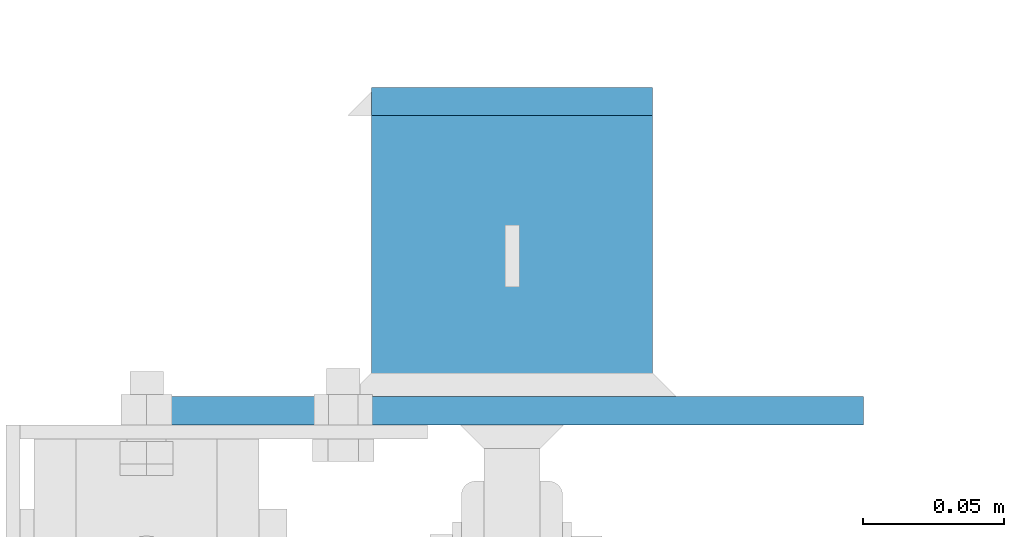
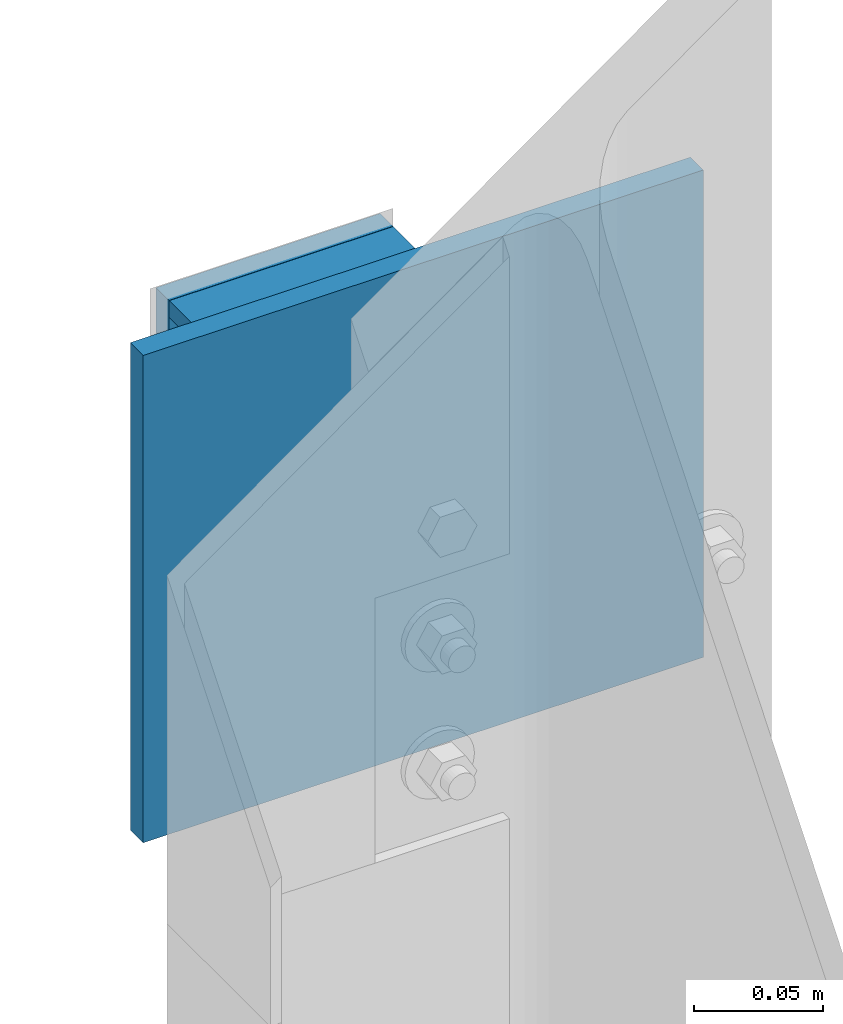
# One storey, part 94 of 496: 3 beams, 1 element without a shape of its own.
"""IFC2X3 building model written with IfcOpenShell, lengths in millimetres."""

import ifcopenshell
import ifcopenshell.guid

model = None  # the IFC model being written
_history = None  # IfcOwnerHistory: only IFC2X3 demands one
_inside = {}  # id of a spatial element -> (the spatial element, [elements in it])
_under = {}  # id of a project, library or spatial element -> (it, [spatial elements below it])
_declared = {}  # id of a project -> (the project, [libraries it declares])
_typed = {}  # id of a type object -> (the type object, [elements of that type])
_made_of = {}  # id of a material, layer set ... -> (it, [elements and type objects made of it])


def new_model(schema):
    """Start an empty IFC model of exactly this schema.

    Asked for "IFC4X3", IfcOpenShell would pick the latest addendum, in which some entities
    have other attributes; the version numbers below select the first issue.
    IFC2X3 requires an IfcOwnerHistory on every rooted entity: one is made here for all.
    """
    global model, _history
    if schema == "IFC4X3":
        model = ifcopenshell.file(schema_version=(4, 3, 0, 0))
    else:
        model = ifcopenshell.file(schema=schema)
    _inside.clear()
    _under.clear()
    _declared.clear()
    _typed.clear()
    _made_of.clear()
    _history = None
    if model.schema == "IFC2X3":
        org = make("IfcOrganization", Name="unknown")
        user = make(
            "IfcPersonAndOrganization",
            ThePerson=make("IfcPerson", FamilyName="unknown"),
            TheOrganization=org,
        )
        app = make(
            "IfcApplication",
            ApplicationDeveloper=org,
            Version="unknown",
            ApplicationFullName="unknown",
            ApplicationIdentifier="unknown",
        )
        _history = make(
            "IfcOwnerHistory",
            OwningUser=user,
            OwningApplication=app,
            ChangeAction="ADDED",
            CreationDate=0,
        )
    return model


def make(cls, **values):
    """One entity of the class cls with the attributes given. An attribute that is None is left unset."""
    return model.create_entity(
        cls, **{name: value for name, value in values.items() if value is not None}
    )


def rooted(cls, **values):
    """An entity with a GlobalId (a new one), such as an element, a storey or a relation."""
    return make(cls, GlobalId=ifcopenshell.guid.new(), OwnerHistory=_history, **values)


def si_unit(unit_type, name, prefix=None):
    """IfcSIUnit, for example si_unit("LENGTHUNIT", "METRE", prefix="MILLI")."""
    return make("IfcSIUnit", UnitType=unit_type, Prefix=prefix, Name=name)


def assignment(units):
    """IfcUnitAssignment: the units of a project."""
    return None if units is None else make("IfcUnitAssignment", Units=units)


def point(xyz):
    """IfcCartesianPoint."""
    return None if xyz is None else make("IfcCartesianPoint", Coordinates=xyz)


def direction(xyz):
    """IfcDirection."""
    return None if xyz is None else make("IfcDirection", DirectionRatios=xyz)


def frame(location, z_axis=None, x_axis=None):
    """IfcAxis2Placement3D, a coordinate frame: its origin and axes. An axis left out is left unset."""
    return make(
        "IfcAxis2Placement3D",
        Location=point(location),
        Axis=direction(z_axis),
        RefDirection=direction(x_axis),
    )


def frame_2d(location, x_axis=None):
    """IfcAxis2Placement2D, a coordinate frame in the plane: its origin and x axis."""
    return make(
        "IfcAxis2Placement2D", Location=point(location), RefDirection=direction(x_axis)
    )


def origin_with_axes():
    """The frame at (0, 0, 0) with the z axis (0, 0, 1) and the x axis (1, 0, 0) written out."""
    return frame((0.0, 0.0, 0.0), z_axis=(0.0, 0.0, 1.0), x_axis=(1.0, 0.0, 0.0))


def origin_2d_with_axis():
    """The frame at (0, 0) in the plane with the x axis (1, 0) written out."""
    return frame_2d((0.0, 0.0), x_axis=(1.0, 0.0))


def place(relative_to, where):
    """IfcLocalPlacement: puts the frame where relative to a parent placement (None: the world)."""
    return make(
        "IfcLocalPlacement", PlacementRelTo=relative_to, RelativePlacement=where
    )


def context(
    kind, dimensions, precision=None, world=None, true_north=None, identifier=None
):
    """IfcGeometricRepresentationContext, for example the 3D "Model" context."""
    return make(
        "IfcGeometricRepresentationContext",
        ContextIdentifier=identifier,
        ContextType=kind,
        CoordinateSpaceDimension=dimensions,
        Precision=precision,
        WorldCoordinateSystem=world,
        TrueNorth=true_north,
    )


def subcontext(parent, identifier, kind, view, scale=None):
    """IfcGeometricRepresentationSubContext, for example "Body" below "Model"."""
    return make(
        "IfcGeometricRepresentationSubContext",
        ContextIdentifier=identifier,
        ContextType=kind,
        ParentContext=parent,
        TargetScale=scale,
        TargetView=view,
    )


def project(units=None, contexts=None):
    """IfcProject with its units and contexts."""
    return rooted(
        "IfcProject",
        Name="project",
        RepresentationContexts=contexts,
        UnitsInContext=assignment(units),
    )


def spatial(cls, under=None, at=None, **own):
    """A site, building, storey or space (cls), placed at a placement, below another one or the project."""
    s = rooted(cls, ObjectPlacement=at, **own)
    if under is not None:
        _under.setdefault(under.id(), (under, []))[1].append(s)
    return s


def profile(cls, at=None, kind="AREA", **sizes):
    """A parametric profile (cls). Its sizes go by their IFC names, for example OverallWidth=200.0."""
    return make(cls, ProfileType=kind, Position=at, **sizes)


def rectangle(**sizes):
    """IfcRectangleProfileDef."""
    return profile("IfcRectangleProfileDef", **sizes)


def i_section(**sizes):
    """IfcIShapeProfileDef."""
    return profile("IfcIShapeProfileDef", **sizes)


def extrude(swept, where, along, depth):
    """IfcExtrudedAreaSolid: the profile swept, set in the frame where, extruded along a direction by depth."""
    return make(
        "IfcExtrudedAreaSolid",
        SweptArea=swept,
        Position=where,
        ExtrudedDirection=direction(along),
        Depth=depth,
    )


def shape(context_of_items, identifier, shape_type, items):
    """IfcShapeRepresentation: the items that make up one representation, for example the "Body"."""
    return make(
        "IfcShapeRepresentation",
        ContextOfItems=context_of_items,
        RepresentationIdentifier=identifier,
        RepresentationType=shape_type,
        Items=items,
    )


def material(Name=None, Category=None):
    """IfcMaterial."""
    return make("IfcMaterial", Name=Name, Category=Category)


def made_of(thing, what):
    """Note that an element or type object is made of a material, layer set ...; save() writes the relation."""
    if what is not None:
        _made_of.setdefault(what.id(), (what, []))[1].append(thing)
    return thing


def type_object(cls, material=None, **own):
    """A type object (cls), such as IfcWallType, which elements share."""
    return made_of(rooted(cls, **own), material)


def element(
    cls,
    number,
    at=None,
    inside=None,
    cuts=None,
    type_object=None,
    material=None,
    context=None,
    identifier="Body",
    shape_type=None,
    held_by="IfcProductDefinitionShape",
    body=None,
    shapes=None,
    **own,
):
    """One element of the class cls, such as IfcWall. Its Tag is "e" and its number.

    at: its placement. inside: the storey or other place that contains it. cuts: it is an
    opening in that element (IfcRelVoidsElement). A single representation is given by context,
    identifier, shape_type and body (its items); several are given by shapes. held_by: the class
    of the entity that holds the representations. save() writes the other relations.
    """
    e = rooted(cls, Tag="e%d" % number, ObjectPlacement=at, **own)
    if body is not None:
        shapes = [shape(context, identifier, shape_type, body)]
    if shapes is not None:
        e.Representation = make(held_by, Representations=shapes)
    if inside is not None:
        _inside.setdefault(inside.id(), (inside, []))[1].append(e)
    if cuts is not None:
        rooted(
            "IfcRelVoidsElement", RelatingBuildingElement=cuts, RelatedOpeningElement=e
        )
    if type_object is not None:
        _typed.setdefault(type_object.id(), (type_object, []))[1].append(e)
    return made_of(e, material)


def aggregate(whole, parts):
    """IfcRelAggregates: a whole, such as a stair, and the parts it consists of."""
    return rooted("IfcRelAggregates", RelatingObject=whole, RelatedObjects=parts)


def save(model, path):
    """Write the relations noted so far, then the file.

    IfcRelAggregates (storeys below a building ...), IfcRelContainedInSpatialStructure (elements
    in a storey), IfcRelDefinesByType, IfcRelAssociatesMaterial and IfcRelDeclares: one each for
    every whole, place, type object, material and project.
    """
    for whole, parts in _under.values():
        aggregate(whole, parts)
    for where, things in _inside.values():
        rooted(
            "IfcRelContainedInSpatialStructure",
            RelatedElements=things,
            RelatingStructure=where,
        )
    for kind, things in _typed.values():
        rooted("IfcRelDefinesByType", RelatedObjects=things, RelatingType=kind)
    for what, things in _made_of.values():
        rooted("IfcRelAssociatesMaterial", RelatedObjects=things, RelatingMaterial=what)
    for by, libraries in _declared.values():
        rooted("IfcRelDeclares", RelatingContext=by, RelatedDefinitions=libraries)
    model.write(path)


model = new_model("IFC2X3")

# Units and contexts
model_context = context("Model", 3, precision=1e-05, world=origin_with_axes())
body_context = subcontext(model_context, "Body", "Model", "MODEL_VIEW")
ifc_project = project(units=[si_unit("LENGTHUNIT", "METRE", prefix="MILLI"), si_unit("AREAUNIT", "SQUARE_METRE"), si_unit("VOLUMEUNIT", "CUBIC_METRE"), si_unit("MASSUNIT", "GRAM", prefix="KILO"), si_unit("TIMEUNIT", "SECOND"), si_unit("PLANEANGLEUNIT", "RADIAN"), si_unit("SOLIDANGLEUNIT", "STERADIAN"), si_unit("THERMODYNAMICTEMPERATUREUNIT", "DEGREE_CELSIUS"), si_unit("LUMINOUSINTENSITYUNIT", "LUMEN")], contexts=[model_context])

# Site, building, storey
site_placement = place(None, origin_with_axes())
site = spatial("IfcSite", under=ifc_project, at=site_placement, CompositionType="ELEMENT")
building_placement = place(site_placement, origin_with_axes())
building = spatial("IfcBuilding", under=site, at=building_placement, Name="Undefined", CompositionType="ELEMENT")
storey_placement = place(building_placement, origin_with_axes())
storey = spatial("IfcBuildingStorey", under=building, at=storey_placement, Name="Undefined", CompositionType="ELEMENT", Elevation=0.0)

# Assembly, beams
assembly_placement = place(storey_placement, origin_with_axes())
assembly = element("IfcElementAssembly", 1, at=assembly_placement, inside=storey, AssemblyPlace="NOTDEFINED", PredefinedType="NOTDEFINED")
ifc_material_1 = material(Name="Undefined/S235-E24")
beam_type_1 = type_object("IfcBeamType", PredefinedType="NOTDEFINED")
beam_1_placement = place(assembly_placement, frame((0.0, 15505.0, 3363.0), z_axis=(-1.0, 0.0, 0.0), x_axis=(0.0, 0.0, -1.0)))
beam_1 = element("IfcBeam", 2, at=beam_1_placement, type_object=beam_type_1, material=ifc_material_1, Name="PLAT", context=body_context, shape_type="SweptSolid", body=[
    extrude(rectangle(XDim=10.0, YDim=100.0, at=origin_2d_with_axis()), frame((96.0, 0.0, 0.0), z_axis=(-1.0, 0.0, 0.0), x_axis=(0.0, -1.0, 0.0)), (0.0, 0.0, 1.0), 96.0),
])
ifc_material_2 = material(Name="Undefined/S275-E28")
beam_type_2 = type_object("IfcBeamType", Name="HEA100", PredefinedType="NOTDEFINED")
beam_2_placement = place(assembly_placement, frame((0.0, 15400.0, 3315.0), z_axis=(0.0, 0.0, 1.0), x_axis=(0.0, 1.0, 0.0)))
beam_2 = element("IfcBeam", 3, at=beam_2_placement, type_object=beam_type_2, material=ifc_material_2, ObjectType="HEA100", context=body_context, shape_type="SweptSolid", body=[
    extrude(i_section(OverallWidth=100.0, OverallDepth=96.0, WebThickness=5.0, FlangeThickness=8.0, FilletRadius=12.0, at=origin_2d_with_axis()), frame((100.000000000021, 5.72981662116945e-11, -4.09272615797818e-12), z_axis=(-1.0, 0.0, 0.0), x_axis=(0.0, -1.0, 0.0)), (0.0, 0.0, 1.0), 100.0),
])
beam_type_3 = type_object("IfcBeamType", PredefinedType="NOTDEFINED")
beam_3_placement = place(assembly_placement, frame((0.0, 15395.0, 3430.0), z_axis=(-1.0, 0.0, 0.0), x_axis=(0.0, 0.0, -1.0)))
beam_3 = element("IfcBeam", 4, at=beam_3_placement, type_object=beam_type_3, material=ifc_material_1, context=body_context, shape_type="SweptSolid", body=[
    extrude(rectangle(XDim=10.0, YDim=250.0, at=origin_2d_with_axis()), frame((230.0, 0.0, 0.0), z_axis=(-1.0, 0.0, 0.0), x_axis=(0.0, -1.0, 0.0)), (0.0, 0.0, 1.0), 230.0),
])
aggregate(assembly, [beam_1, beam_2, beam_3])

save(model, "model.ifc")
